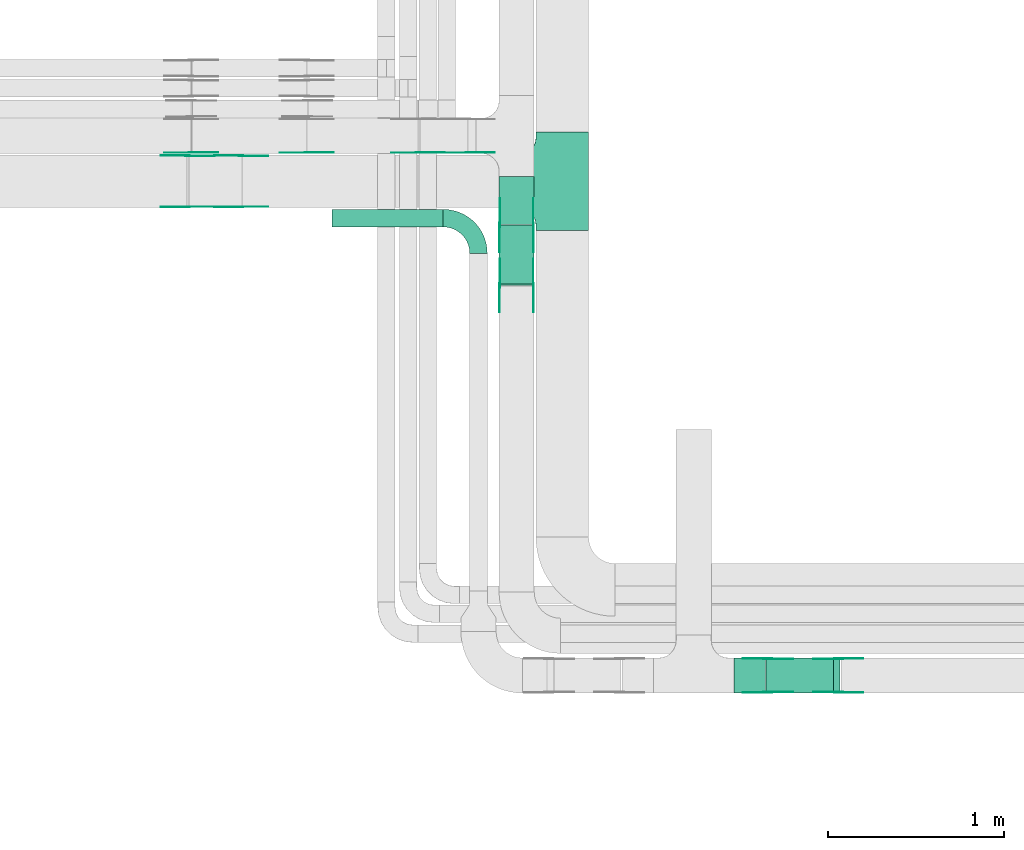
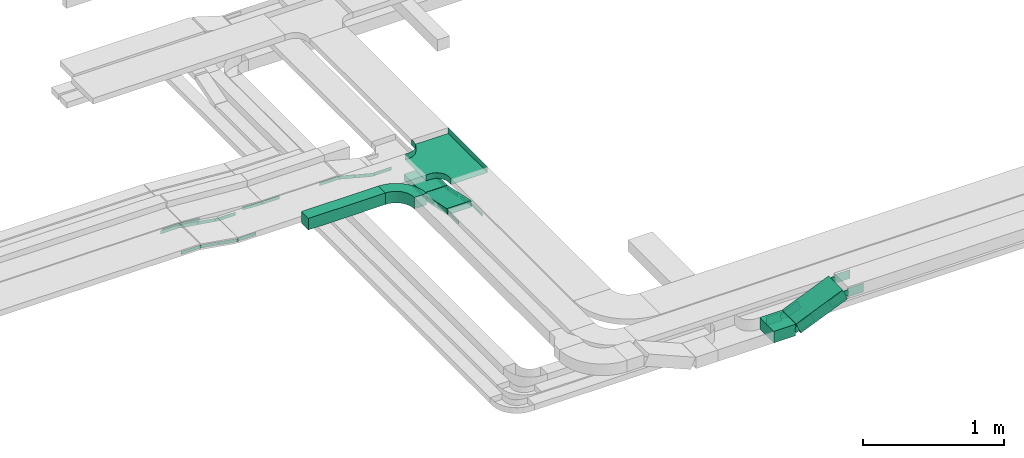
# One storey, part 4 of 19: 34 flow fittings, 5 flow segments.
"""IFC2X3 building model written with IfcOpenShell, lengths in millimetres."""

from ifc_helpers import new_model, entity, si_unit, converted_unit, derived_unit, direction, frame, frame_2d, origin, place, context, subcontext, project, spatial, polyline, circle_curve, parameter, trimmed, segment, composite_curve, rectangle, outline, extrude, faceted_brep, source, transform, mapped, material, type_object, type_shapes, element, save


model = new_model("IFC2X3")

# Units and contexts
model_context = context("Model", 3, precision=0.01, world=origin(), true_north=direction((6.12303176911189e-17, 1.0)))
body_context = subcontext(model_context, "Body", "Model", "MODEL_VIEW")
ifc_project = project(units=[si_unit("LENGTHUNIT", "METRE", prefix="MILLI"), si_unit("AREAUNIT", "SQUARE_METRE"), si_unit("VOLUMEUNIT", "CUBIC_METRE"), converted_unit("PLANEANGLEUNIT", "DEGREE", entity("IfcRatioMeasure", 0.0174532925199433), si_unit("PLANEANGLEUNIT", "RADIAN"), dimensions=[0, 0, 0, 0, 0, 0, 0]), si_unit("MASSUNIT", "GRAM", prefix="KILO"), derived_unit("MASSDENSITYUNIT", [(si_unit("MASSUNIT", "GRAM", prefix="KILO"), 1), (si_unit("LENGTHUNIT", "METRE"), -3)]), derived_unit("MOMENTOFINERTIAUNIT", [(si_unit("LENGTHUNIT", "METRE"), 4)]), si_unit("TIMEUNIT", "SECOND"), si_unit("FREQUENCYUNIT", "HERTZ"), si_unit("THERMODYNAMICTEMPERATUREUNIT", "DEGREE_CELSIUS"), derived_unit("THERMALTRANSMITTANCEUNIT", [(si_unit("MASSUNIT", "GRAM", prefix="KILO"), 1), (si_unit("THERMODYNAMICTEMPERATUREUNIT", "KELVIN"), -1), (si_unit("TIMEUNIT", "SECOND"), -3)]), derived_unit("VOLUMETRICFLOWRATEUNIT", [(si_unit("LENGTHUNIT", "METRE"), 3), (si_unit("TIMEUNIT", "SECOND"), -1)]), derived_unit("MASSFLOWRATEUNIT", [(si_unit("MASSUNIT", "GRAM", prefix="KILO"), 1), (si_unit("TIMEUNIT", "SECOND"), -1)]), derived_unit("ROTATIONALFREQUENCYUNIT", [(si_unit("TIMEUNIT", "SECOND"), -1)]), si_unit("ELECTRICCURRENTUNIT", "AMPERE"), si_unit("ELECTRICVOLTAGEUNIT", "VOLT"), si_unit("POWERUNIT", "WATT"), si_unit("FORCEUNIT", "NEWTON", prefix="KILO"), si_unit("ILLUMINANCEUNIT", "LUX"), si_unit("LUMINOUSFLUXUNIT", "LUMEN"), si_unit("LUMINOUSINTENSITYUNIT", "CANDELA"), derived_unit("USERDEFINED", [(si_unit("MASSUNIT", "GRAM", prefix="KILO"), -1), (si_unit("LENGTHUNIT", "METRE"), -2), (si_unit("TIMEUNIT", "SECOND"), 3), (si_unit("LUMINOUSFLUXUNIT", "LUMEN"), 1)]), derived_unit("LINEARVELOCITYUNIT", [(si_unit("LENGTHUNIT", "METRE"), 1), (si_unit("TIMEUNIT", "SECOND"), -1)]), si_unit("PRESSUREUNIT", "PASCAL"), derived_unit("USERDEFINED", [(si_unit("LENGTHUNIT", "METRE"), -2), (si_unit("MASSUNIT", "GRAM", prefix="KILO"), 1), (si_unit("TIMEUNIT", "SECOND"), -2)]), derived_unit("LINEARFORCEUNIT", [(si_unit("MASSUNIT", "GRAM", prefix="KILO"), 1), (si_unit("LENGTHUNIT", "METRE"), 1), (si_unit("TIMEUNIT", "SECOND"), -2), (si_unit("LENGTHUNIT", "METRE"), -1)]), derived_unit("PLANARFORCEUNIT", [(si_unit("MASSUNIT", "GRAM", prefix="KILO"), 1), (si_unit("LENGTHUNIT", "METRE"), 1), (si_unit("TIMEUNIT", "SECOND"), -2), (si_unit("LENGTHUNIT", "METRE"), -2)])], contexts=[model_context])

# Site, building, storey
site_placement = place(None, frame((0.0, -0.00077364408347762, 0.0)))
site = spatial("IfcSite", under=ifc_project, at=site_placement, CompositionType="ELEMENT")
building_placement = place(site_placement, origin())
building = spatial("IfcBuilding", under=site, at=building_placement, CompositionType="ELEMENT")
storey_placement = place(building_placement, frame((0.0, 0.0, 12000.0)))
storey = spatial("IfcBuildingStorey", under=building, at=storey_placement, CompositionType="ELEMENT", Elevation=12000.0)

# Flow segments
cable_carrier_segment_type = type_object("IfcCableCarrierSegmentType", PredefinedType="CABLETRAYSEGMENT")
flow_segment_1_placement = place(storey_placement, frame((18018.5874268759, 12154.9710146429, 2727.85030390842)))
element("IfcFlowSegment", 1, at=flow_segment_1_placement, inside=storey, type_object=cable_carrier_segment_type, context=body_context, shape_type="SweptSolid", body=[
    extrude(rectangle(XDim=273.824636449433, YDim=199.999999999998, at=frame_2d((-1.08002495835535e-12, 0.0), x_axis=(1.0, 0.0))), frame((100.0, 136.912318224718, 0.0), z_axis=(0.0, 0.0, 1.0), x_axis=(0.0, -1.0, 0.0)), (0.0, 0.0, 1.0), 50.0000000000016),
])
flow_segment_2_placement = place(storey_placement, frame((18018.5874268759, 11806.4587280659, 2729.23824515959)))
element("IfcFlowSegment", 2, at=flow_segment_2_placement, inside=storey, type_object=cable_carrier_segment_type, context=body_context, shape_type="SweptSolid", body=[
    extrude(rectangle(XDim=50.0000000000024, YDim=342.797863451643, at=frame_2d((0.0, 0.0), x_axis=(0.0, 1.0))), frame((0.0, 172.851246106449, 60.0895317170204), z_axis=(1.0, 0.0, 0.0), x_axis=(0.0, -0.978147600734828, 0.207911690812948)), (0.0, 0.0, 1.0), 199.999999999998),
])
flow_segment_3_placement = place(storey_placement, frame((19539.1795601184, 9487.44715307422, 2637.3085380416)))
element("IfcFlowSegment", 3, at=flow_segment_3_placement, inside=storey, type_object=cable_carrier_segment_type, context=body_context, shape_type="SweptSolid", body=[
    extrude(rectangle(XDim=100.000000000001, YDim=200.0, at=frame_2d((0.0, -1.08713038571295e-12), x_axis=(1.0, 0.0))), frame((19.5365564242341, 100.0, 46.0252426727179), z_axis=(0.920504853454354, 0.0, 0.390731128484766), x_axis=(-0.390731128484766, 0.0, 0.920504853454354)), (0.0, 0.0, 1.0), 414.563208392916),
])
flow_segment_4_placement = place(storey_placement, frame((19356.5152668448, 9487.44715307422, 2628.65031167227)))
element("IfcFlowSegment", 4, at=flow_segment_4_placement, inside=storey, type_object=cable_carrier_segment_type, context=body_context, shape_type="SweptSolid", body=[
    extrude(rectangle(XDim=179.180863906, YDim=200.0, at=frame_2d((1.08713038571295e-12, -1.08713038571295e-12), x_axis=(1.0, 0.0))), frame((89.5904319529989, 100.0, 0.0), z_axis=(0.0, 0.0, 1.0), x_axis=(-1.0, 0.0, 0.0)), (0.0, 0.0, 1.0), 99.9999999999989),
])
flow_segment_5_placement = place(storey_placement, frame((17069.2184887994, 12140.3959585079, 2800.0)))
element("IfcFlowSegment", 5, at=flow_segment_5_placement, inside=storey, type_object=cable_carrier_segment_type, context=body_context, shape_type="SweptSolid", body=[
    extrude(rectangle(XDim=631.454921335267, YDim=99.9999999999989, at=frame_2d((0.0, 1.08357767203415e-12), x_axis=(1.0, 0.0))), frame((315.727460667634, 50.0, 0.0), z_axis=(0.0, 0.0, 1.0), x_axis=(-1.0, 0.0, 0.0)), (0.0, 0.0, 1.0), 99.9999999999989),
])

# Flow fittings
ifc_material_1 = material(Name="G")
cable_carrier_fitting_type_1 = type_object("IfcCableCarrierFittingType", PredefinedType="NOTDEFINED", material=ifc_material_1)
shared_shape_1 = source(origin(), body_context, "Body", "SweptSolid", [
    extrude(outline(composite_curve([segment(trimmed(circle_curve(frame_2d((-44.5901162790698, 0.0), x_axis=(1.0, 0.0)), 12.5), [parameter(90.0000000000007)], [parameter(270.0)], True, "PARAMETER"), True, "CONTINUOUS"), segment(polyline([(-44.5901162790697, -12.5), (-33.0901162790698, -12.5)]), True, "CONTINUOUS"), segment(polyline([(-33.0901162790698, -12.5), (-31.2296511627907, -14.5)]), True, "CONTINUOUS"), segment(polyline([(-31.2296511627907, -14.5), (108.90988372093, -14.5)]), True, "CONTINUOUS"), segment(polyline([(108.90988372093, -14.5), (108.90988372093, 14.5)]), True, "CONTINUOUS"), segment(polyline([(108.90988372093, 14.5), (-31.2296511627907, 14.5)]), True, "CONTINUOUS"), segment(polyline([(-31.2296511627907, 14.5), (-33.0901162790698, 12.5)]), True, "CONTINUOUS"), segment(polyline([(-33.0901162790698, 12.5), (-44.5901162790699, 12.5)]), True, "CONTINUOUS")], self_intersect=False)), frame((44.5901162790698, 0.0, 0.0), z_axis=(0.0, 0.0, -1.0), x_axis=(1.0, 0.0, 0.0)), (0.0, 0.0, -1.0), 2.0),
])
type_shapes(cable_carrier_fitting_type_1, [shared_shape_1])
for number, where, z_axis, x_axis in (
    (6, (18023.1274268657, 12150.9229918202, 2752.8503039084), (-1.0, 0.0, 0.0), (0.0, -0.978147600733805, 0.207911690817761)),
    (7, (18214.047426886, 11807.6969565245, 2825.80524984481), (1.0, 0.0, 0.0), (0.0, -1.0, 0.0)),
    (8, (16550.9424818654, 12545.2510308088, 2825.0), (0.0, 1.0, 0.0), (-0.986849163973513, 0.0, 0.161643829343339)),
    (9, (16245.6882794678, 12254.3310307885, 2875.0), (0.0, -1.0, 0.0), (-1.0, 0.0, 0.0)),
    (10, (16266.3444383805, 12563.3356510822, 2875.0), (0.0, -1.0, 0.0), (-1.0, 0.0, 0.0)),
    (11, (17557.7781053636, 12563.3356510822, 2825.0), (0.0, -1.0, 0.0), (-1.0, 0.0, 0.0)),
):
    element("IfcFlowFitting", number, at=place(storey_placement, frame(where, z_axis=z_axis, x_axis=x_axis)), inside=storey, type_object=cable_carrier_fitting_type_1, material=ifc_material_1, context=body_context, shape_type="MappedRepresentation", body=[
        mapped(shared_shape_1, transform((0.0, 0.0, 0.0), scale=1.0)),
    ])
cable_carrier_fitting_type_2 = type_object("IfcCableCarrierFittingType", PredefinedType="NOTDEFINED", material=ifc_material_1)
shared_shape_2 = source(origin(), body_context, "Body", "SweptSolid", [
    extrude(outline(composite_curve([segment(trimmed(circle_curve(frame_2d((-44.5901162790697, 0.0), x_axis=(1.0, 0.0)), 12.5), [parameter(90.0000000000007)], [parameter(270.0)], True, "PARAMETER"), True, "CONTINUOUS"), segment(polyline([(-44.5901162790697, -12.5), (-33.0901162790697, -12.5)]), True, "CONTINUOUS"), segment(polyline([(-33.0901162790697, -12.5), (-31.2296511627907, -14.5)]), True, "CONTINUOUS"), segment(polyline([(-31.2296511627907, -14.5), (108.90988372093, -14.5)]), True, "CONTINUOUS"), segment(polyline([(108.90988372093, -14.5), (108.90988372093, 14.5)]), True, "CONTINUOUS"), segment(polyline([(108.90988372093, 14.5), (-31.2296511627907, 14.5)]), True, "CONTINUOUS"), segment(polyline([(-31.2296511627907, 14.5), (-33.0901162790698, 12.5)]), True, "CONTINUOUS"), segment(polyline([(-33.0901162790698, 12.5), (-44.5901162790699, 12.5)]), True, "CONTINUOUS")], self_intersect=False)), frame((44.5901162790697, 0.0, 0.0)), (0.0, 0.0, 1.0), 2.0),
])
type_shapes(cable_carrier_fitting_type_2, [shared_shape_2])
for number, where, z_axis, x_axis in (
    (12, (18214.047426886, 12150.9229918202, 2752.8503039084), (1.0, 0.0, 0.0), (0.0, -0.978147600733805, 0.207911690817761)),
    (13, (18023.1274268657, 11807.6969565245, 2825.80524984481), (-1.0, 0.0, 0.0), (0.0, -1.0, 0.0)),
    (14, (16550.9424818654, 12254.3310307885, 2825.0), (0.0, -1.0, 0.0), (-0.986849163973513, 0.0, 0.161643829343339)),
    (15, (16245.6882794678, 12545.2510308088, 2875.0), (0.0, 1.0, 0.0), (-1.0, 0.0, 0.0)),
    (16, (16925.5152856638, 12563.3356510822, 2825.0), (0.0, -1.0, 0.0), (-0.997135526115969, 0.0, 0.0756355905472349)),
    (17, (17841.1625871757, 12563.3356510822, 2752.85030390839), (0.0, -1.0, 0.0), (-0.969084530600981, 0.0, 0.246728945504732)),
):
    element("IfcFlowFitting", number, at=place(storey_placement, frame(where, z_axis=z_axis, x_axis=x_axis)), inside=storey, type_object=cable_carrier_fitting_type_2, material=ifc_material_1, context=body_context, shape_type="MappedRepresentation", body=[
        mapped(shared_shape_2, transform((0.0, 0.0, 0.0), scale=1.0)),
    ])
cable_carrier_fitting_type_3 = type_object("IfcCableCarrierFittingType", PredefinedType="NOTDEFINED", material=ifc_material_1)
shared_shape_3 = source(origin(), body_context, "Body", "SweptSolid", [
    extrude(outline(composite_curve([segment(trimmed(circle_curve(frame_2d((-44.5901162790698, 0.0), x_axis=(1.0, 0.0)), 12.5), [parameter(90.0000000000007)], [parameter(270.0)], True, "PARAMETER"), True, "CONTINUOUS"), segment(polyline([(-44.5901162790697, -12.5), (-33.0901162790698, -12.5)]), True, "CONTINUOUS"), segment(polyline([(-33.0901162790698, -12.5), (-31.2296511627907, -14.5)]), True, "CONTINUOUS"), segment(polyline([(-31.2296511627907, -14.5), (108.90988372093, -14.5)]), True, "CONTINUOUS"), segment(polyline([(108.90988372093, -14.5), (108.90988372093, 14.5)]), True, "CONTINUOUS"), segment(polyline([(108.90988372093, 14.5), (-31.2296511627907, 14.5)]), True, "CONTINUOUS"), segment(polyline([(-31.2296511627907, 14.5), (-33.0901162790698, 12.5)]), True, "CONTINUOUS"), segment(polyline([(-33.0901162790698, 12.5), (-44.5901162790699, 12.5)]), True, "CONTINUOUS")], self_intersect=False)), frame((44.5901162790698, 0.0, 0.0), z_axis=(0.0, 0.0, -1.0), x_axis=(1.0, 0.0, 0.0)), (0.0, 0.0, -1.0), 2.0),
])
type_shapes(cable_carrier_fitting_type_3, [shared_shape_3])
for number, where, z_axis, x_axis in (
    (18, (18212.047426886, 12150.9229918202, 2752.85030390841), (1.0, 0.0, 0.0), (0.0, 1.0, 0.0)),
    (19, (18025.1274268657, 11807.6969565245, 2825.8052498448), (-1.0, 0.0, 0.0), (0.0, 0.978147600733806, -0.207911690817758)),
    (20, (16550.9424818654, 12256.3310307885, 2825.0), (0.0, -1.0, 0.0), (1.0, 0.0, 0.0)),
    (21, (16245.6882794678, 12543.2510308088, 2875.0), (0.0, 1.0, 0.0), (0.986849163973514, 0.0, -0.161643829343333)),
    (22, (16925.5152856638, 12565.3356510822, 2825.0), (0.0, -1.0, 0.0), (1.0, 0.0, 0.0)),
    (23, (17841.1625871757, 12565.3356510822, 2752.85030390839), (0.0, -1.0, 0.0), (1.0, 0.0, 0.0)),
):
    element("IfcFlowFitting", number, at=place(storey_placement, frame(where, z_axis=z_axis, x_axis=x_axis)), inside=storey, type_object=cable_carrier_fitting_type_3, material=ifc_material_1, context=body_context, shape_type="MappedRepresentation", body=[
        mapped(shared_shape_3, transform((0.0, 0.0, 0.0), scale=1.0)),
    ])
cable_carrier_fitting_type_4 = type_object("IfcCableCarrierFittingType", PredefinedType="NOTDEFINED", material=ifc_material_1)
shared_shape_4 = source(origin(), body_context, "Body", "SweptSolid", [
    extrude(outline(composite_curve([segment(trimmed(circle_curve(frame_2d((-44.5901162790697, 0.0), x_axis=(1.0, 0.0)), 12.5), [parameter(90.0000000000007)], [parameter(270.0)], True, "PARAMETER"), True, "CONTINUOUS"), segment(polyline([(-44.5901162790697, -12.5), (-33.0901162790697, -12.5)]), True, "CONTINUOUS"), segment(polyline([(-33.0901162790697, -12.5), (-31.2296511627907, -14.5)]), True, "CONTINUOUS"), segment(polyline([(-31.2296511627907, -14.5), (108.90988372093, -14.5)]), True, "CONTINUOUS"), segment(polyline([(108.90988372093, -14.5), (108.90988372093, 14.5)]), True, "CONTINUOUS"), segment(polyline([(108.90988372093, 14.5), (-31.2296511627907, 14.5)]), True, "CONTINUOUS"), segment(polyline([(-31.2296511627907, 14.5), (-33.0901162790698, 12.5)]), True, "CONTINUOUS"), segment(polyline([(-33.0901162790698, 12.5), (-44.5901162790699, 12.5)]), True, "CONTINUOUS")], self_intersect=False)), frame((44.5901162790697, 0.0, 0.0)), (0.0, 0.0, 1.0), 2.0),
])
type_shapes(cable_carrier_fitting_type_4, [shared_shape_4])
for number, where, z_axis, x_axis in (
    (24, (18025.1274268657, 12150.9229918202, 2752.85030390841), (-1.0, 0.0, 0.0), (0.0, 1.0, 0.0)),
    (25, (18212.047426886, 11807.6969565245, 2825.8052498448), (1.0, 0.0, 0.0), (0.0, 0.978147600733806, -0.207911690817758)),
    (26, (16550.9424818654, 12543.2510308088, 2825.0), (0.0, 1.0, 0.0), (1.0, 0.0, 0.0)),
    (27, (16245.6882794678, 12256.3310307885, 2875.0), (0.0, -1.0, 0.0), (0.986849163973514, 0.0, -0.161643829343333)),
    (28, (16266.3444383805, 12565.3356510822, 2875.0), (0.0, -1.0, 0.0), (0.99713552611597, 0.0, -0.0756355905472288)),
    (29, (17557.7781053635, 12565.3356510822, 2825.0), (0.0, -1.0, 0.0), (0.96908453060098, 0.0, -0.246728945504733)),
):
    element("IfcFlowFitting", number, at=place(storey_placement, frame(where, z_axis=z_axis, x_axis=x_axis)), inside=storey, type_object=cable_carrier_fitting_type_4, material=ifc_material_1, context=body_context, shape_type="MappedRepresentation", body=[
        mapped(shared_shape_4, transform((0.0, 0.0, 0.0), scale=1.0)),
    ])
ifc_material_2 = material()
cable_carrier_fitting_type_5 = type_object("IfcCableCarrierFittingType", PredefinedType="NOTDEFINED", material=ifc_material_2)
shared_shape_5 = source(origin(), body_context, "Body", "Brep", [
    faceted_brep([(-153.407417371086, -224.118095489753, 25.0), (-150.0, -250.0, 25.0), (-150.0, -280.0, 25.0), (-149.199999999993, -280.0, 25.0), (-149.199999999993, -250.0, 25.0), (-152.634676710055, -223.911040253671, 25.0), (-162.704639298522, -199.600000000004, 25.0), (-178.723636456391, -178.7236364564, 25.0), (-199.599999999996, -162.704639298532, 25.0), (-223.911040253663, -152.634676710066, 25.0), (-250.0, -149.200000000004, 25.0), (-280.0, -149.200000000004, 25.0), (-280.0, -150.0, 25.0), (-250.0, -150.0, 25.0), (-224.118095489745, -153.407417371099, 25.0), (-200.0, -163.397459621561, 25.0), (-179.28932188134, -179.289321881349, 25.0), (-163.39745962155, -200.0, 25.0), (280.0, -150.0, 25.0), (280.0, -149.200000000004, 25.0), (250.0, -149.200000000007, 25.0), (223.911040253719, -152.634676710068, 25.0), (199.600000000048, -162.704639298534, 25.0), (178.723636456437, -178.7236364564, 25.0), (162.70463929856, -199.600000000004, 25.0), (152.634676710083, -223.91104025367, 25.0), (149.200000000009, -250.0, 25.0), (149.200000000007, -280.0, 25.0), (150.0, -280.0, 25.0), (150.0, -250.0, 25.0), (153.407417371116, -224.118095489752, 25.0), (163.39745962159, -200.0, 25.0), (179.289321881388, -179.289321881351, 25.0), (200.0, -163.397459621564, 25.0), (224.118095489802, -153.407417371102, 25.0), (250.0, -150.0, 25.0), (280.0, 149.199999999995, 25.0), (280.0, 150.0, 25.0), (-280.0, 150.0, 25.0), (-280.0, 149.199999999995, 25.0), (-280.0, -150.0, -25.0), (-280.0, 150.0, -25.0), (280.0, 150.0, -25.0), (280.0, -150.0, -25.0), (250.0, -150.0, -25.0), (224.118095489802, -153.407417371102, -25.0), (200.0, -163.397459621564, -25.0), (179.289321881388, -179.289321881351, -25.0), (163.39745962159, -200.0, -25.0), (153.407417371116, -224.118095489752, -25.0), (150.0, -250.0, -25.0), (150.0, -280.0, -25.0), (-150.0, -280.0, -25.0), (-150.0, -250.0, -25.0), (-153.407417371086, -224.118095489753, -25.0), (-163.39745962155, -200.0, -25.0), (-179.28932188134, -179.289321881349, -25.0), (-200.0, -163.397459621561, -25.0), (-224.118095489745, -153.407417371099, -25.0), (-250.0, -150.0, -25.0), (-150.0, -250.0, -24.199999999986), (149.200000000007, -280.0, -24.199999999986), (-149.199999999993, -280.0, -24.199999999986), (-149.199999999993, -250.0, -24.199999999986), (-250.0, -149.200000000004, -24.199999999986), (-280.0, -149.200000000004, -24.199999999986), (280.0, -149.200000000004, -24.199999999986), (250.0, -149.200000000004, -24.199999999986), (-280.0, 149.199999999995, -24.199999999986), (-250.0, -150.0, -24.199999999986), (250.0, -150.0, -24.199999999986), (280.0, 149.199999999995, -24.199999999986), (149.200000000009, -250.0, -24.199999999986), (150.0, -250.0, -24.199999999986), (-223.911040253663, -152.634676710066, -24.199999999986), (-199.599999999996, -162.704639298532, -24.199999999986), (-178.723636456391, -178.7236364564, -24.199999999986), (-162.704639298522, -199.600000000004, -24.199999999986), (-152.634676710055, -223.911040253671, -24.199999999986), (152.634676710083, -223.911040253671, -24.199999999986), (162.70463929856, -199.600000000004, -24.199999999986), (178.723636456436, -178.723636456401, -24.199999999986), (199.600000000047, -162.704639298534, -24.199999999986), (223.911040253719, -152.634676710069, -24.199999999986)], [[[0, 1, 2, 3, 4, 5, 6, 7, 8, 9, 10, 11, 12, 13, 14, 15, 16, 17]], [[18, 19, 20, 21, 22, 23, 24, 25, 26, 27, 28, 29, 30, 31, 32, 33, 34, 35]], [[36, 37, 38, 39]], [[40, 41, 42, 43, 44, 45, 46, 47, 48, 49, 50, 51, 52, 53, 54, 55, 56, 57, 58, 59]], [[2, 1, 60, 53, 52]], [[3, 2, 52, 51, 28, 27, 61, 62]], [[4, 3, 62, 63]], [[11, 10, 64, 65]], [[20, 19, 66, 67]], [[39, 38, 41, 40, 12, 11, 65, 68]], [[13, 12, 40, 59, 69]], [[18, 35, 70, 44, 43]], [[19, 18, 43, 42, 37, 36, 71, 66]], [[27, 26, 72, 61]], [[29, 28, 51, 50, 73]], [[38, 37, 42, 41]], [[36, 39, 68, 71]], [[68, 65, 64, 74, 75, 76, 77, 78, 63, 62, 61, 72, 79, 80, 81, 82, 83, 67, 66, 71]], [[14, 13, 69, 59, 58]], [[58, 57, 15, 14]], [[15, 57, 56, 16]], [[0, 17, 55, 54]], [[0, 54, 53, 60, 1]], [[55, 17, 16, 56]], [[5, 4, 63, 78]], [[6, 5, 78, 77]], [[7, 6, 77, 76]], [[8, 7, 76, 75]], [[9, 8, 75, 74]], [[10, 9, 74, 64]], [[21, 20, 67, 83]], [[22, 21, 83, 82]], [[23, 22, 82, 81]], [[81, 80, 24, 23]], [[24, 80, 79, 25]], [[79, 72, 26, 25]], [[30, 29, 73, 50, 49]], [[31, 30, 49, 48]], [[31, 48, 47, 32]], [[33, 32, 47, 46]], [[45, 34, 33, 46]], [[34, 45, 44, 70, 35]]]),
])
type_shapes(cable_carrier_fitting_type_5, [shared_shape_5])
flow_fitting_1_placement = place(storey_placement, frame((18378.5368087494, 12399.7910307987, 2825.0), z_axis=(0.0, 0.0, 1.0), x_axis=(0.0, -1.0, 0.0)))
element("IfcFlowFitting", 30, at=flow_fitting_1_placement, inside=storey, type_object=cable_carrier_fitting_type_5, material=ifc_material_2, Name="470_DKC_S5_T", context=body_context, shape_type="MappedRepresentation", body=[
    mapped(shared_shape_5, transform((0.0, 0.0, 0.0), scale=1.0)),
])
cable_carrier_fitting_type_6 = type_object("IfcCableCarrierFittingType", PredefinedType="NOTDEFINED", material=ifc_material_1)
shared_shape_6 = source(origin(), body_context, "Body", "SweptSolid", [
    extrude(outline(composite_curve([segment(trimmed(circle_curve(frame_2d((-41.4651162790697, 0.0), x_axis=(1.0, 0.0)), 25.0), [parameter(90.0000000000007)], [parameter(270.0)], True, "PARAMETER"), True, "CONTINUOUS"), segment(polyline([(-41.4651162790697, -25.0), (-29.9651162790697, -25.0)]), True, "CONTINUOUS"), segment(polyline([(-29.9651162790697, -25.0), (-28.1046511627907, -38.5)]), True, "CONTINUOUS"), segment(polyline([(-28.1046511627907, -38.5), (99.5348837209303, -38.5)]), True, "CONTINUOUS"), segment(polyline([(99.5348837209303, -38.5), (99.5348837209303, 38.5)]), True, "CONTINUOUS"), segment(polyline([(99.5348837209303, 38.5), (-28.1046511627907, 38.5)]), True, "CONTINUOUS"), segment(polyline([(-28.1046511627907, 38.5), (-29.9651162790697, 25.0)]), True, "CONTINUOUS"), segment(polyline([(-29.9651162790697, 25.0), (-41.46511627907, 25.0)]), True, "CONTINUOUS")], self_intersect=False)), frame((41.4651162790697, 0.0, 0.0), z_axis=(0.0, 0.0, -1.0), x_axis=(1.0, 0.0, 0.0)), (0.0, 0.0, -1.0), 2.0),
])
type_shapes(cable_carrier_fitting_type_6, [shared_shape_6])
for number, where, z_axis, x_axis in (
    (31, (19547.6825549197, 9682.90715308438, 2678.65031167225), (0.0, 1.0, 0.0), (-1.0, 0.0, 0.0)),
    (32, (19951.3571235548, 9682.90715308438, 2850.0), (0.0, 1.0, 0.0), (1.0, 0.0, 0.0)),
):
    element("IfcFlowFitting", number, at=place(storey_placement, frame(where, z_axis=z_axis, x_axis=x_axis)), inside=storey, type_object=cable_carrier_fitting_type_6, material=ifc_material_1, context=body_context, shape_type="MappedRepresentation", body=[
        mapped(shared_shape_6, transform((0.0, 0.0, 0.0), scale=1.0)),
    ])
cable_carrier_fitting_type_7 = type_object("IfcCableCarrierFittingType", PredefinedType="NOTDEFINED", material=ifc_material_1)
shared_shape_7 = source(origin(), body_context, "Body", "SweptSolid", [
    extrude(outline(composite_curve([segment(trimmed(circle_curve(frame_2d((-41.4651162790697, 0.0), x_axis=(1.0, 0.0)), 25.0), [parameter(90.0000000000007)], [parameter(270.0)], True, "PARAMETER"), True, "CONTINUOUS"), segment(polyline([(-41.4651162790697, -25.0), (-29.9651162790697, -25.0)]), True, "CONTINUOUS"), segment(polyline([(-29.9651162790697, -25.0), (-28.1046511627907, -38.5)]), True, "CONTINUOUS"), segment(polyline([(-28.1046511627907, -38.5), (99.5348837209303, -38.5)]), True, "CONTINUOUS"), segment(polyline([(99.5348837209303, -38.5), (99.5348837209303, 38.5)]), True, "CONTINUOUS"), segment(polyline([(99.5348837209303, 38.5), (-28.1046511627907, 38.5)]), True, "CONTINUOUS"), segment(polyline([(-28.1046511627907, 38.5), (-29.9651162790697, 25.0)]), True, "CONTINUOUS"), segment(polyline([(-29.9651162790697, 25.0), (-41.46511627907, 25.0)]), True, "CONTINUOUS")], self_intersect=False)), frame((41.4651162790697, 0.0, 0.0)), (0.0, 0.0, 1.0), 2.0),
])
type_shapes(cable_carrier_fitting_type_7, [shared_shape_7])
for number, where, z_axis, x_axis in (
    (33, (19547.6825549197, 9491.98715306406, 2678.65031167225), (0.0, -1.0, 0.0), (-1.0, 0.0, 0.0)),
    (34, (19951.3571235548, 9491.98715306406, 2850.0), (0.0, -1.0, 0.0), (1.0, 0.0, 0.0)),
):
    element("IfcFlowFitting", number, at=place(storey_placement, frame(where, z_axis=z_axis, x_axis=x_axis)), inside=storey, type_object=cable_carrier_fitting_type_7, material=ifc_material_1, context=body_context, shape_type="MappedRepresentation", body=[
        mapped(shared_shape_7, transform((0.0, 0.0, 0.0), scale=1.0)),
    ])
cable_carrier_fitting_type_8 = type_object("IfcCableCarrierFittingType", PredefinedType="NOTDEFINED", material=ifc_material_1)
shared_shape_8 = source(origin(), body_context, "Body", "SweptSolid", [
    extrude(outline(composite_curve([segment(trimmed(circle_curve(frame_2d((-41.4651162790697, 0.0), x_axis=(1.0, 0.0)), 25.0), [parameter(90.0000000000007)], [parameter(270.0)], True, "PARAMETER"), True, "CONTINUOUS"), segment(polyline([(-41.4651162790697, -25.0), (-29.9651162790697, -25.0)]), True, "CONTINUOUS"), segment(polyline([(-29.9651162790697, -25.0), (-28.1046511627907, -38.5)]), True, "CONTINUOUS"), segment(polyline([(-28.1046511627907, -38.5), (99.5348837209303, -38.5)]), True, "CONTINUOUS"), segment(polyline([(99.5348837209303, -38.5), (99.5348837209303, 38.5)]), True, "CONTINUOUS"), segment(polyline([(99.5348837209303, 38.5), (-28.1046511627907, 38.5)]), True, "CONTINUOUS"), segment(polyline([(-28.1046511627907, 38.5), (-29.9651162790697, 25.0)]), True, "CONTINUOUS"), segment(polyline([(-29.9651162790697, 25.0), (-41.46511627907, 25.0)]), True, "CONTINUOUS")], self_intersect=False)), frame((41.4651162790697, 0.0, 0.0), z_axis=(0.0, 0.0, -1.0), x_axis=(1.0, 0.0, 0.0)), (0.0, 0.0, -1.0), 2.0),
])
type_shapes(cable_carrier_fitting_type_8, [shared_shape_8])
for number, where, z_axis, x_axis in (
    (35, (19547.6825549197, 9493.98715306407, 2678.65031167225), (0.0, -1.0, 0.0), (0.920504853452433, 0.0, 0.390731128489292)),
    (36, (19951.3571235548, 9493.98715306406, 2850.0), (0.0, -1.0, 0.0), (-0.920504853454359, 0.0, -0.390731128484754)),
):
    element("IfcFlowFitting", number, at=place(storey_placement, frame(where, z_axis=z_axis, x_axis=x_axis)), inside=storey, type_object=cable_carrier_fitting_type_8, material=ifc_material_1, context=body_context, shape_type="MappedRepresentation", body=[
        mapped(shared_shape_8, transform((0.0, 0.0, 0.0), scale=1.0)),
    ])
cable_carrier_fitting_type_9 = type_object("IfcCableCarrierFittingType", PredefinedType="NOTDEFINED", material=ifc_material_1)
shared_shape_9 = source(origin(), body_context, "Body", "SweptSolid", [
    extrude(outline(composite_curve([segment(trimmed(circle_curve(frame_2d((-41.4651162790697, 0.0), x_axis=(1.0, 0.0)), 25.0), [parameter(90.0000000000007)], [parameter(270.0)], True, "PARAMETER"), True, "CONTINUOUS"), segment(polyline([(-41.4651162790697, -25.0), (-29.9651162790697, -25.0)]), True, "CONTINUOUS"), segment(polyline([(-29.9651162790697, -25.0), (-28.1046511627907, -38.5)]), True, "CONTINUOUS"), segment(polyline([(-28.1046511627907, -38.5), (99.5348837209303, -38.5)]), True, "CONTINUOUS"), segment(polyline([(99.5348837209303, -38.5), (99.5348837209303, 38.5)]), True, "CONTINUOUS"), segment(polyline([(99.5348837209303, 38.5), (-28.1046511627907, 38.5)]), True, "CONTINUOUS"), segment(polyline([(-28.1046511627907, 38.5), (-29.9651162790697, 25.0)]), True, "CONTINUOUS"), segment(polyline([(-29.9651162790697, 25.0), (-41.46511627907, 25.0)]), True, "CONTINUOUS")], self_intersect=False)), frame((41.4651162790697, 0.0, 0.0)), (0.0, 0.0, 1.0), 2.0),
])
type_shapes(cable_carrier_fitting_type_9, [shared_shape_9])
for number, where, z_axis, x_axis in (
    (37, (19547.6825549197, 9680.90715308438, 2678.65031167225), (0.0, 1.0, 0.0), (0.920504853452433, 0.0, 0.390731128489292)),
    (38, (19951.3571235548, 9680.90715308438, 2850.0), (0.0, 1.0, 0.0), (-0.920504853454359, 0.0, -0.390731128484754)),
):
    element("IfcFlowFitting", number, at=place(storey_placement, frame(where, z_axis=z_axis, x_axis=x_axis)), inside=storey, type_object=cable_carrier_fitting_type_9, material=ifc_material_1, context=body_context, shape_type="MappedRepresentation", body=[
        mapped(shared_shape_9, transform((0.0, 0.0, 0.0), scale=1.0)),
    ])
cable_carrier_fitting_type_10 = type_object("IfcCableCarrierFittingType", Name="470_DKC_S5_Variable Angle Elbow 0-45:-", PredefinedType="NOTDEFINED", material=ifc_material_2)
shared_shape_10 = source(origin(), body_context, "Body", "SweptSolid", [
    extrude(outline(composite_curve([segment(polyline([(-100.749999999999, -150.250000000001), (-99.7499999999981, -150.250000000001)]), True, "CONTINUOUS"), segment(trimmed(circle_curve(frame_2d((-99.7500000000006, 99.7499999999987), x_axis=(0.0, -1.0)), 250.0), [parameter(0.0)], [parameter(90.0000000000001)], True, "PARAMETER"), True, "CONTINUOUS"), segment(polyline([(150.249999999999, 99.7500000000013), (150.249999999999, 100.750000000001)]), True, "CONTINUOUS"), segment(polyline([(150.249999999999, 100.750000000001), (50.2499999999992, 100.750000000001)]), True, "CONTINUOUS"), segment(polyline([(50.2499999999992, 100.750000000001), (50.2499999999992, 99.7500000000002)]), True, "CONTINUOUS"), segment(trimmed(circle_curve(frame_2d((-99.7500000000006, 99.7499999999987), x_axis=(0.0, -1.0)), 150.0), [parameter(0.0)], [parameter(90.0000000000001)], True, "PARAMETER"), False, "CONTINUOUS"), segment(polyline([(-99.7499999999989, -50.2500000000011), (-100.75, -50.2500000000011)]), True, "CONTINUOUS"), segment(polyline([(-100.75, -50.2500000000011), (-100.749999999999, -150.250000000001)]), True, "CONTINUOUS")], self_intersect=False)), frame((-100.249999999991, 100.249999999992, -50.0)), (0.0, 0.0, 1.0), 100.0),
])
type_shapes(cable_carrier_fitting_type_10, [shared_shape_10])
flow_fitting_2_placement = place(storey_placement, frame((17901.6734101346, 12190.3959585079, 2850.0), z_axis=(0.0, 0.0, 1.0), x_axis=(0.0, 1.0, 0.0)))
element("IfcFlowFitting", 39, at=flow_fitting_2_placement, inside=storey, type_object=cable_carrier_fitting_type_10, material=ifc_material_2, Name="470_DKC_S5_Variable Angle Elbow 0-45:-", ObjectType="470_DKC_S5_Variable Angle Elbow 0-45:-", context=body_context, shape_type="MappedRepresentation", body=[
    mapped(shared_shape_10, transform((0.0, 0.0, 0.0), scale=1.0)),
])

save(model, "model.ifc")
